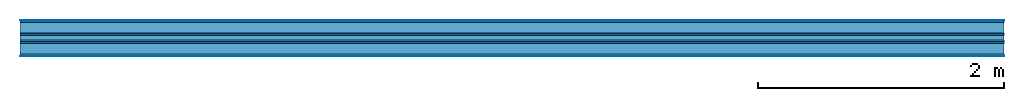
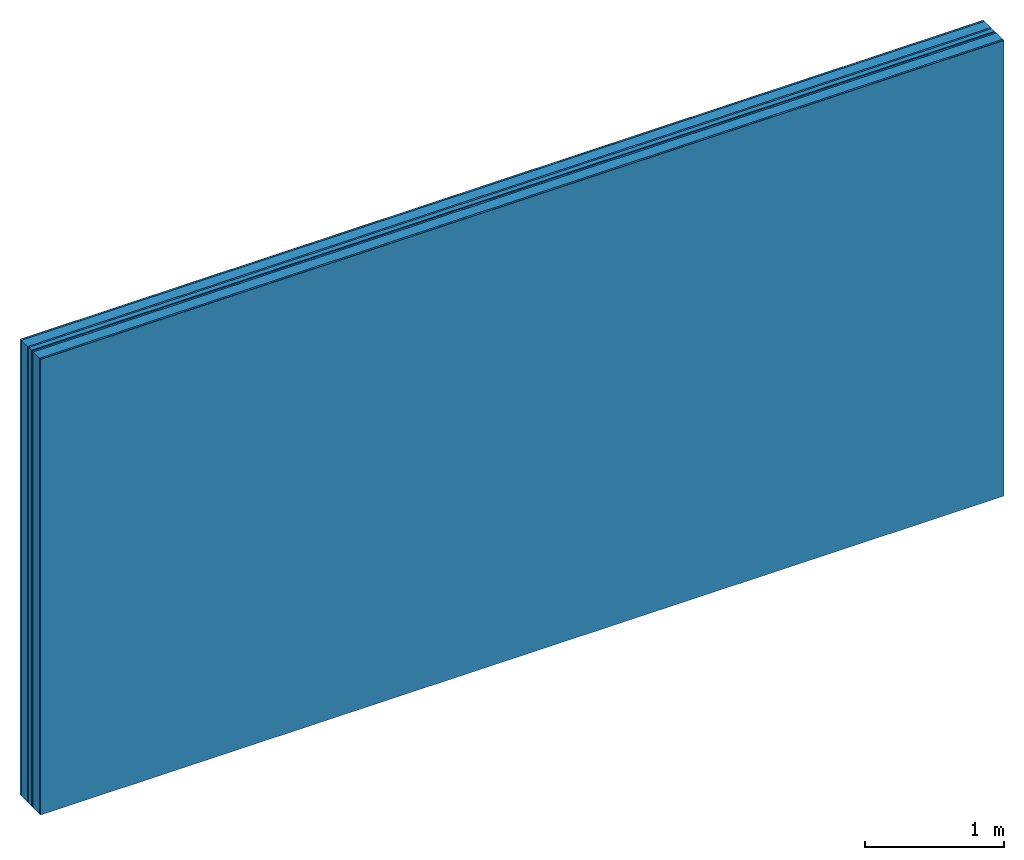
# One storey: 8 plates, 2 members, 1 element without a shape of its own.
"""IFC4 building model written with IfcOpenShell, lengths in metres."""

import ifcopenshell
import ifcopenshell.guid

model = None  # the IFC model being written
_history = None  # IfcOwnerHistory: only IFC2X3 demands one
_inside = {}  # id of a spatial element -> (the spatial element, [elements in it])
_under = {}  # id of a project, library or spatial element -> (it, [spatial elements below it])
_declared = {}  # id of a project -> (the project, [libraries it declares])
_typed = {}  # id of a type object -> (the type object, [elements of that type])
_made_of = {}  # id of a material, layer set ... -> (it, [elements and type objects made of it])


def new_model(schema):
    """Start an empty IFC model of exactly this schema.

    Asked for "IFC4X3", IfcOpenShell would pick the latest addendum, in which some entities
    have other attributes; the version numbers below select the first issue.
    IFC2X3 requires an IfcOwnerHistory on every rooted entity: one is made here for all.
    """
    global model, _history
    if schema == "IFC4X3":
        model = ifcopenshell.file(schema_version=(4, 3, 0, 0))
    else:
        model = ifcopenshell.file(schema=schema)
    _inside.clear()
    _under.clear()
    _declared.clear()
    _typed.clear()
    _made_of.clear()
    _history = None
    if model.schema == "IFC2X3":
        org = make("IfcOrganization", Name="unknown")
        user = make(
            "IfcPersonAndOrganization",
            ThePerson=make("IfcPerson", FamilyName="unknown"),
            TheOrganization=org,
        )
        app = make(
            "IfcApplication",
            ApplicationDeveloper=org,
            Version="unknown",
            ApplicationFullName="unknown",
            ApplicationIdentifier="unknown",
        )
        _history = make(
            "IfcOwnerHistory",
            OwningUser=user,
            OwningApplication=app,
            ChangeAction="ADDED",
            CreationDate=0,
        )
    return model


def make(cls, **values):
    """One entity of the class cls with the attributes given. An attribute that is None is left unset."""
    return model.create_entity(
        cls, **{name: value for name, value in values.items() if value is not None}
    )


def rooted(cls, **values):
    """An entity with a GlobalId (a new one), such as an element, a storey or a relation."""
    return make(cls, GlobalId=ifcopenshell.guid.new(), OwnerHistory=_history, **values)


def si_unit(unit_type, name, prefix=None):
    """IfcSIUnit, for example si_unit("LENGTHUNIT", "METRE", prefix="MILLI")."""
    return make("IfcSIUnit", UnitType=unit_type, Prefix=prefix, Name=name)


def derived_unit(unit_type, elements):
    """IfcDerivedUnit: a product of units, each with its exponent."""
    return make(
        "IfcDerivedUnit",
        Elements=[
            make("IfcDerivedUnitElement", Unit=unit, Exponent=power)
            for unit, power in elements
        ],
        UnitType=unit_type,
    )


def assignment(units):
    """IfcUnitAssignment: the units of a project."""
    return None if units is None else make("IfcUnitAssignment", Units=units)


def point(xyz):
    """IfcCartesianPoint."""
    return None if xyz is None else make("IfcCartesianPoint", Coordinates=xyz)


def direction(xyz):
    """IfcDirection."""
    return None if xyz is None else make("IfcDirection", DirectionRatios=xyz)


def frame(location, z_axis=None, x_axis=None):
    """IfcAxis2Placement3D, a coordinate frame: its origin and axes. An axis left out is left unset."""
    return make(
        "IfcAxis2Placement3D",
        Location=point(location),
        Axis=direction(z_axis),
        RefDirection=direction(x_axis),
    )


def frame_2d(location, x_axis=None):
    """IfcAxis2Placement2D, a coordinate frame in the plane: its origin and x axis."""
    return make(
        "IfcAxis2Placement2D", Location=point(location), RefDirection=direction(x_axis)
    )


def origin():
    """The frame at (0, 0, 0) with its axes left unset."""
    return frame((0.0, 0.0, 0.0))


def origin_with_axes():
    """The frame at (0, 0, 0) with the z axis (0, 0, 1) and the x axis (1, 0, 0) written out."""
    return frame((0.0, 0.0, 0.0), z_axis=(0.0, 0.0, 1.0), x_axis=(1.0, 0.0, 0.0))


def place(relative_to, where):
    """IfcLocalPlacement: puts the frame where relative to a parent placement (None: the world)."""
    return make(
        "IfcLocalPlacement", PlacementRelTo=relative_to, RelativePlacement=where
    )


def context(
    kind, dimensions, precision=None, world=None, true_north=None, identifier=None
):
    """IfcGeometricRepresentationContext, for example the 3D "Model" context."""
    return make(
        "IfcGeometricRepresentationContext",
        ContextIdentifier=identifier,
        ContextType=kind,
        CoordinateSpaceDimension=dimensions,
        Precision=precision,
        WorldCoordinateSystem=world,
        TrueNorth=true_north,
    )


def project(units=None, contexts=None):
    """IfcProject with its units and contexts."""
    return rooted(
        "IfcProject",
        Name="project",
        RepresentationContexts=contexts,
        UnitsInContext=assignment(units),
    )


def spatial(cls, under=None, at=None, **own):
    """A site, building, storey or space (cls), placed at a placement, below another one or the project."""
    s = rooted(cls, ObjectPlacement=at, **own)
    if under is not None:
        _under.setdefault(under.id(), (under, []))[1].append(s)
    return s


def profile(cls, at=None, kind="AREA", **sizes):
    """A parametric profile (cls). Its sizes go by their IFC names, for example OverallWidth=200.0."""
    return make(cls, ProfileType=kind, Position=at, **sizes)


def rectangle(**sizes):
    """IfcRectangleProfileDef."""
    return profile("IfcRectangleProfileDef", **sizes)


def extrude(swept, where, along, depth):
    """IfcExtrudedAreaSolid: the profile swept, set in the frame where, extruded along a direction by depth."""
    return make(
        "IfcExtrudedAreaSolid",
        SweptArea=swept,
        Position=where,
        ExtrudedDirection=direction(along),
        Depth=depth,
    )


def shape(context_of_items, identifier, shape_type, items):
    """IfcShapeRepresentation: the items that make up one representation, for example the "Body"."""
    return make(
        "IfcShapeRepresentation",
        ContextOfItems=context_of_items,
        RepresentationIdentifier=identifier,
        RepresentationType=shape_type,
        Items=items,
    )


def material(Name=None, Category=None):
    """IfcMaterial."""
    return make("IfcMaterial", Name=Name, Category=Category)


def layer(
    of_material, thickness, ventilated=None, Name=None, Category=None, Priority=None
):
    """IfcMaterialLayer: one layer of a wall or slab, of a material (None: an air gap)."""
    return make(
        "IfcMaterialLayer",
        Material=of_material,
        LayerThickness=thickness,
        IsVentilated=ventilated,
        Name=Name,
        Category=Category,
        Priority=Priority,
    )


def layer_set(layers, Name=None):
    """IfcMaterialLayerSet."""
    return make("IfcMaterialLayerSet", MaterialLayers=layers, LayerSetName=Name)


def made_of(thing, what):
    """Note that an element or type object is made of a material, layer set ...; save() writes the relation."""
    if what is not None:
        _made_of.setdefault(what.id(), (what, []))[1].append(thing)
    return thing


def type_object(cls, material=None, **own):
    """A type object (cls), such as IfcWallType, which elements share."""
    return made_of(rooted(cls, **own), material)


def element(
    cls,
    number,
    at=None,
    inside=None,
    cuts=None,
    type_object=None,
    material=None,
    context=None,
    identifier="Body",
    shape_type=None,
    held_by="IfcProductDefinitionShape",
    body=None,
    shapes=None,
    **own,
):
    """One element of the class cls, such as IfcWall. Its Tag is "e" and its number.

    at: its placement. inside: the storey or other place that contains it. cuts: it is an
    opening in that element (IfcRelVoidsElement). A single representation is given by context,
    identifier, shape_type and body (its items); several are given by shapes. held_by: the class
    of the entity that holds the representations. save() writes the other relations.
    """
    e = rooted(cls, Tag="e%d" % number, ObjectPlacement=at, **own)
    if body is not None:
        shapes = [shape(context, identifier, shape_type, body)]
    if shapes is not None:
        e.Representation = make(held_by, Representations=shapes)
    if inside is not None:
        _inside.setdefault(inside.id(), (inside, []))[1].append(e)
    if cuts is not None:
        rooted(
            "IfcRelVoidsElement", RelatingBuildingElement=cuts, RelatedOpeningElement=e
        )
    if type_object is not None:
        _typed.setdefault(type_object.id(), (type_object, []))[1].append(e)
    return made_of(e, material)


def aggregate(whole, parts):
    """IfcRelAggregates: a whole, such as a stair, and the parts it consists of."""
    return rooted("IfcRelAggregates", RelatingObject=whole, RelatedObjects=parts)


def save(model, path):
    """Write the relations noted so far, then the file.

    IfcRelAggregates (storeys below a building ...), IfcRelContainedInSpatialStructure (elements
    in a storey), IfcRelDefinesByType, IfcRelAssociatesMaterial and IfcRelDeclares: one each for
    every whole, place, type object, material and project.
    """
    for whole, parts in _under.values():
        aggregate(whole, parts)
    for where, things in _inside.values():
        rooted(
            "IfcRelContainedInSpatialStructure",
            RelatedElements=things,
            RelatingStructure=where,
        )
    for kind, things in _typed.values():
        rooted("IfcRelDefinesByType", RelatedObjects=things, RelatingType=kind)
    for what, things in _made_of.values():
        rooted("IfcRelAssociatesMaterial", RelatedObjects=things, RelatingMaterial=what)
    for by, libraries in _declared.values():
        rooted("IfcRelDeclares", RelatingContext=by, RelatedDefinitions=libraries)
    model.write(path)


model = new_model("IFC4")

# Units and contexts
plan_context = context("Plan", 3, precision=1e-05, world=origin(), true_north=direction((0.0, 1.0)))
model_context = context("Model", 3, precision=1e-05, world=origin(), true_north=direction((0.0, 1.0)))
ifc_project = project(units=[si_unit("LENGTHUNIT", "METRE"), derived_unit("SOUNDPRESSUREUNIT", [(si_unit("PRESSUREUNIT", "PASCAL", prefix="MICRO"), 0)]), si_unit("ENERGYUNIT", "JOULE", prefix="MEGA"), si_unit("MASSUNIT", "GRAM", prefix="KILO"), derived_unit("THERMALTRANSMITTANCEUNIT", [(si_unit("POWERUNIT", "WATT"), 1), (si_unit("AREAUNIT", "SQUARE_METRE"), -1), (si_unit("THERMODYNAMICTEMPERATUREUNIT", "KELVIN"), -1)]), derived_unit("AREADENSITYUNIT", [(si_unit("MASSUNIT", "GRAM", prefix="KILO"), 1), (si_unit("AREAUNIT", "SQUARE_METRE"), -1)]), derived_unit("USERDEFINED", [(si_unit("ENERGYUNIT", "JOULE", prefix="MEGA"), 1), (si_unit("AREAUNIT", "SQUARE_METRE"), -1)])], contexts=[plan_context, model_context])

# Site, building, storey
site = spatial("IfcSite", under=ifc_project)
building_placement = place(None, origin())
building = spatial("IfcBuilding", under=site, at=building_placement)
storey_placement = place(building_placement, origin())
storey = spatial("IfcBuildingStorey", under=building, at=storey_placement)

# Wall, members, plates
ifc_material_1 = material(Category="04.001")
ifc_layer_1 = layer(ifc_material_1, 0.003, Name="Surface")
ifc_material_2 = material(Name="DFH2IR Knauf Diamant hard- plasterboard", Category="03.007")
ifc_layer_2 = layer(ifc_material_2, 0.015, Name="room side 1st layer")
ifc_material_3 = material(Name="of the art")
ifc_layer_3 = layer(ifc_material_3, 0.0, Name="Bond")
ifc_layer_4 = layer(None, 0.09, Name="Support")
ifc_layer_5 = layer(ifc_material_3, 0.0, Name="Bond")
ifc_layer_6 = layer(ifc_material_2, 0.015, Name="outside 1st layer")
ifc_material_4 = material(Category="10.008")
ifc_layer_7 = layer(ifc_material_4, 0.04, Name="Intermediate insulation")
ifc_material_5 = material(Name="Air")
ifc_layer_8 = layer(ifc_material_5, 0.01, Name="Air gap")
ifc_layer_9 = layer(ifc_material_2, 0.015, Name="outside 1st layer")
ifc_layer_10 = layer(ifc_material_3, 0.0, Name="Bond")
ifc_layer_11 = layer(None, 0.09, Name="Support")
ifc_layer_12 = layer(ifc_material_3, 0.0, Name="Bond")
ifc_layer_13 = layer(ifc_material_2, 0.015, Name="room side 1st layer")
ifc_layer_14 = layer(ifc_material_1, 0.003, Name="Surface")
ifc_layer_set = layer_set([ifc_layer_1, ifc_layer_2, ifc_layer_3, ifc_layer_4, ifc_layer_5, ifc_layer_6, ifc_layer_7, ifc_layer_8, ifc_layer_9, ifc_layer_10, ifc_layer_11, ifc_layer_12, ifc_layer_13, ifc_layer_14])
wall_type = type_object("IfcWallType", Name="B0299", PredefinedType="NOTDEFINED", material=ifc_layer_set)
wall_placement = place(None, frame((0.0, 0.0, 0.0), z_axis=(0.0, -1.0, 0.0), x_axis=(1.0, 0.0, 0.0)))
wall = element("IfcWall", 1, at=wall_placement, inside=storey, type_object=wall_type, material=ifc_layer_set, Name="Wall #1")
ifc_material_6 = material(Name="Solid timber panel")
member_1_placement = place(wall_placement, origin())
member_1 = element("IfcMember", 2, at=member_1_placement, material=ifc_material_6, Name="Support", context=plan_context, shape_type="SweptSolid", body=[
    extrude(rectangle(XDim=1.0, YDim=0.09, at=frame_2d((0.5, 0.045), x_axis=(1.0, 0.0))), frame((0.0, 4.0, 0.018), z_axis=(0.0, -1.0, 0.0), x_axis=(1.0, 0.0, 0.0)), (0.0, 0.0, 1.0), 4.0),
    extrude(rectangle(XDim=1.0, YDim=0.09, at=frame_2d((0.5, 0.045), x_axis=(1.0, 0.0))), frame((1.0, 4.0, 0.018), z_axis=(0.0, -1.0, 0.0), x_axis=(1.0, 0.0, 0.0)), (0.0, 0.0, 1.0), 4.0),
    extrude(rectangle(XDim=1.0, YDim=0.09, at=frame_2d((0.5, 0.045), x_axis=(1.0, 0.0))), frame((2.0, 4.0, 0.018), z_axis=(0.0, -1.0, 0.0), x_axis=(1.0, 0.0, 0.0)), (0.0, 0.0, 1.0), 4.0),
    extrude(rectangle(XDim=1.0, YDim=0.09, at=frame_2d((0.5, 0.045), x_axis=(1.0, 0.0))), frame((3.0, 4.0, 0.018), z_axis=(0.0, -1.0, 0.0), x_axis=(1.0, 0.0, 0.0)), (0.0, 0.0, 1.0), 4.0),
    extrude(rectangle(XDim=1.0, YDim=0.09, at=frame_2d((0.5, 0.045), x_axis=(1.0, 0.0))), frame((4.0, 4.0, 0.018), z_axis=(0.0, -1.0, 0.0), x_axis=(1.0, 0.0, 0.0)), (0.0, 0.0, 1.0), 4.0),
    extrude(rectangle(XDim=1.0, YDim=0.09, at=frame_2d((0.5, 0.045), x_axis=(1.0, 0.0))), frame((5.0, 4.0, 0.018), z_axis=(0.0, -1.0, 0.0), x_axis=(1.0, 0.0, 0.0)), (0.0, 0.0, 1.0), 4.0),
    extrude(rectangle(XDim=1.0, YDim=0.09, at=frame_2d((0.5, 0.045), x_axis=(1.0, 0.0))), frame((6.0, 4.0, 0.018), z_axis=(0.0, -1.0, 0.0), x_axis=(1.0, 0.0, 0.0)), (0.0, 0.0, 1.0), 4.0),
    extrude(rectangle(XDim=1.0, YDim=0.09, at=frame_2d((0.5, 0.045), x_axis=(1.0, 0.0))), frame((7.0, 4.0, 0.018), z_axis=(0.0, -1.0, 0.0), x_axis=(1.0, 0.0, 0.0)), (0.0, 0.0, 1.0), 4.0),
])
member_2_placement = place(wall_placement, origin())
member_2 = element("IfcMember", 3, at=member_2_placement, material=ifc_material_6, Name="Support", context=plan_context, shape_type="SweptSolid", body=[
    extrude(rectangle(XDim=1.0, YDim=0.09, at=frame_2d((0.5, 0.045), x_axis=(1.0, 0.0))), frame((0.0, 4.0, 0.188), z_axis=(0.0, -1.0, 0.0), x_axis=(1.0, 0.0, 0.0)), (0.0, 0.0, 1.0), 4.0),
    extrude(rectangle(XDim=1.0, YDim=0.09, at=frame_2d((0.5, 0.045), x_axis=(1.0, 0.0))), frame((1.0, 4.0, 0.188), z_axis=(0.0, -1.0, 0.0), x_axis=(1.0, 0.0, 0.0)), (0.0, 0.0, 1.0), 4.0),
    extrude(rectangle(XDim=1.0, YDim=0.09, at=frame_2d((0.5, 0.045), x_axis=(1.0, 0.0))), frame((2.0, 4.0, 0.188), z_axis=(0.0, -1.0, 0.0), x_axis=(1.0, 0.0, 0.0)), (0.0, 0.0, 1.0), 4.0),
    extrude(rectangle(XDim=1.0, YDim=0.09, at=frame_2d((0.5, 0.045), x_axis=(1.0, 0.0))), frame((3.0, 4.0, 0.188), z_axis=(0.0, -1.0, 0.0), x_axis=(1.0, 0.0, 0.0)), (0.0, 0.0, 1.0), 4.0),
    extrude(rectangle(XDim=1.0, YDim=0.09, at=frame_2d((0.5, 0.045), x_axis=(1.0, 0.0))), frame((4.0, 4.0, 0.188), z_axis=(0.0, -1.0, 0.0), x_axis=(1.0, 0.0, 0.0)), (0.0, 0.0, 1.0), 4.0),
    extrude(rectangle(XDim=1.0, YDim=0.09, at=frame_2d((0.5, 0.045), x_axis=(1.0, 0.0))), frame((5.0, 4.0, 0.188), z_axis=(0.0, -1.0, 0.0), x_axis=(1.0, 0.0, 0.0)), (0.0, 0.0, 1.0), 4.0),
    extrude(rectangle(XDim=1.0, YDim=0.09, at=frame_2d((0.5, 0.045), x_axis=(1.0, 0.0))), frame((6.0, 4.0, 0.188), z_axis=(0.0, -1.0, 0.0), x_axis=(1.0, 0.0, 0.0)), (0.0, 0.0, 1.0), 4.0),
    extrude(rectangle(XDim=1.0, YDim=0.09, at=frame_2d((0.5, 0.045), x_axis=(1.0, 0.0))), frame((7.0, 4.0, 0.188), z_axis=(0.0, -1.0, 0.0), x_axis=(1.0, 0.0, 0.0)), (0.0, 0.0, 1.0), 4.0),
])
plate_1_placement = place(wall_placement, origin())
plate_1 = element("IfcPlate", 4, at=plate_1_placement, material=ifc_material_1, Name="Surface", context=plan_context, shape_type="SweptSolid", body=[
    extrude(rectangle(XDim=8.0, YDim=4.0, at=frame_2d((4.0, 2.0), x_axis=(1.0, 0.0))), origin_with_axes(), (0.0, 0.0, 1.0), 0.003),
])
plate_2_placement = place(wall_placement, origin())
plate_2 = element("IfcPlate", 5, at=plate_2_placement, material=ifc_material_2, Name="room side 1st layer", context=plan_context, shape_type="SweptSolid", body=[
    extrude(rectangle(XDim=8.0, YDim=4.0, at=frame_2d((4.0, 2.0), x_axis=(1.0, 0.0))), frame((0.0, 0.0, 0.003), z_axis=(0.0, 0.0, 1.0), x_axis=(1.0, 0.0, 0.0)), (0.0, 0.0, 1.0), 0.015),
])
plate_3_placement = place(wall_placement, origin())
plate_3 = element("IfcPlate", 6, at=plate_3_placement, material=ifc_material_2, Name="outside 1st layer", context=plan_context, shape_type="SweptSolid", body=[
    extrude(rectangle(XDim=8.0, YDim=4.0, at=frame_2d((4.0, 2.0), x_axis=(1.0, 0.0))), frame((0.0, 0.0, 0.108), z_axis=(0.0, 0.0, 1.0), x_axis=(1.0, 0.0, 0.0)), (0.0, 0.0, 1.0), 0.015),
])
plate_4_placement = place(wall_placement, origin())
plate_4 = element("IfcPlate", 7, at=plate_4_placement, material=ifc_material_4, Name="Intermediate insulation", context=plan_context, shape_type="SweptSolid", body=[
    extrude(rectangle(XDim=8.0, YDim=4.0, at=frame_2d((4.0, 2.0), x_axis=(1.0, 0.0))), frame((0.0, 0.0, 0.123), z_axis=(0.0, 0.0, 1.0), x_axis=(1.0, 0.0, 0.0)), (0.0, 0.0, 1.0), 0.04),
])
plate_5_placement = place(wall_placement, origin())
plate_5 = element("IfcPlate", 8, at=plate_5_placement, material=ifc_material_5, Name="Air gap", context=plan_context, shape_type="SweptSolid", body=[
    extrude(rectangle(XDim=8.0, YDim=4.0, at=frame_2d((4.0, 2.0), x_axis=(1.0, 0.0))), frame((0.0, 0.0, 0.163), z_axis=(0.0, 0.0, 1.0), x_axis=(1.0, 0.0, 0.0)), (0.0, 0.0, 1.0), 0.01),
])
plate_6_placement = place(wall_placement, origin())
plate_6 = element("IfcPlate", 9, at=plate_6_placement, material=ifc_material_2, Name="outside 1st layer", context=plan_context, shape_type="SweptSolid", body=[
    extrude(rectangle(XDim=8.0, YDim=4.0, at=frame_2d((4.0, 2.0), x_axis=(1.0, 0.0))), frame((0.0, 0.0, 0.173), z_axis=(0.0, 0.0, 1.0), x_axis=(1.0, 0.0, 0.0)), (0.0, 0.0, 1.0), 0.015),
])
plate_7_placement = place(wall_placement, origin())
plate_7 = element("IfcPlate", 10, at=plate_7_placement, material=ifc_material_2, Name="room side 1st layer", context=plan_context, shape_type="SweptSolid", body=[
    extrude(rectangle(XDim=8.0, YDim=4.0, at=frame_2d((4.0, 2.0), x_axis=(1.0, 0.0))), frame((0.0, 0.0, 0.278), z_axis=(0.0, 0.0, 1.0), x_axis=(1.0, 0.0, 0.0)), (0.0, 0.0, 1.0), 0.015),
])
plate_8_placement = place(wall_placement, origin())
plate_8 = element("IfcPlate", 11, at=plate_8_placement, material=ifc_material_1, Name="Surface", context=plan_context, shape_type="SweptSolid", body=[
    extrude(rectangle(XDim=8.0, YDim=4.0, at=frame_2d((4.0, 2.0), x_axis=(1.0, 0.0))), frame((0.0, 0.0, 0.293), z_axis=(0.0, 0.0, 1.0), x_axis=(1.0, 0.0, 0.0)), (0.0, 0.0, 1.0), 0.003),
])
aggregate(wall, [plate_1, plate_2, member_1, plate_3, plate_4, plate_5, plate_6, member_2, plate_7, plate_8])

save(model, "model.ifc")
